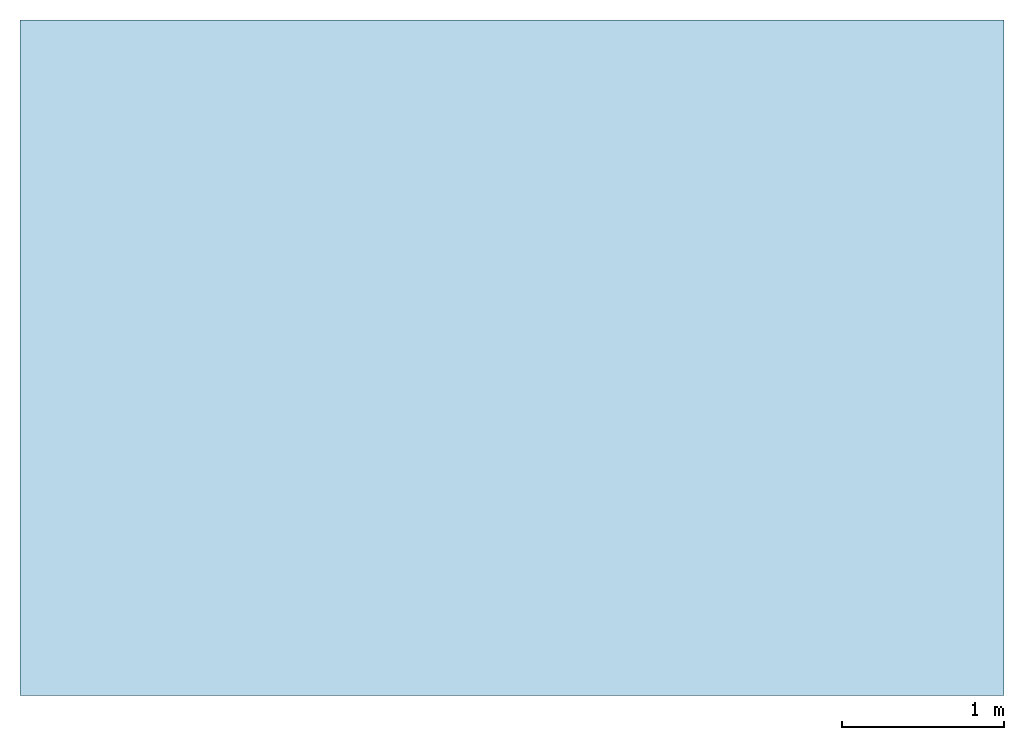
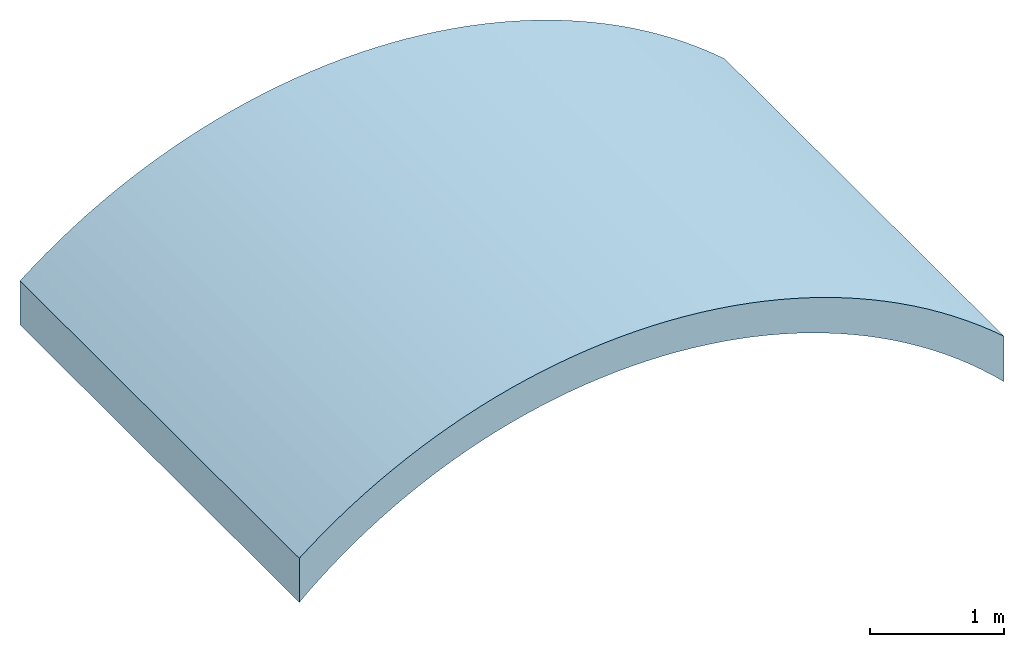
# One storey: 1 roof.
"""IFC4 building model written with IfcOpenShell, lengths in feet."""

from ifc_helpers import new_model, entity, si_unit, converted_unit, derived_unit, direction, frame, origin, place, context, subcontext, project, spatial, material, layer, layer_set, type_object, element, save


model = new_model("IFC4")

# Units and contexts
model_context = context("Model", 3, precision=0.0001, world=origin(), true_north=direction((6.12303176911189e-17, 1.0)))
body_context = subcontext(model_context, "Body", "Model", "MODEL_VIEW")
ifc_project = project(units=[converted_unit("LENGTHUNIT", "FOOT", entity("IfcRatioMeasure", 0.3048), si_unit("LENGTHUNIT", "METRE"), dimensions=[1, 0, 0, 0, 0, 0, 0]), converted_unit("AREAUNIT", "SQUARE FOOT", entity("IfcRatioMeasure", 0.09290304), si_unit("AREAUNIT", "SQUARE_METRE"), dimensions=[2, 0, 0, 0, 0, 0, 0]), converted_unit("VOLUMEUNIT", "CUBIC FOOT", entity("IfcRatioMeasure", 0.028316846592), si_unit("VOLUMEUNIT", "CUBIC_METRE"), dimensions=[3, 0, 0, 0, 0, 0, 0]), converted_unit("PLANEANGLEUNIT", "DEGREE", entity("IfcRatioMeasure", 0.0174532925199433), si_unit("PLANEANGLEUNIT", "RADIAN"), dimensions=[0, 0, 0, 0, 0, 0, 0]), si_unit("MASSUNIT", "GRAM", prefix="KILO"), derived_unit("MASSDENSITYUNIT", [(si_unit("MASSUNIT", "GRAM", prefix="KILO"), 1), (si_unit("LENGTHUNIT", "METRE"), -3)]), derived_unit("MOMENTOFINERTIAUNIT", [(si_unit("LENGTHUNIT", "METRE"), 4)]), si_unit("TIMEUNIT", "SECOND"), si_unit("FREQUENCYUNIT", "HERTZ"), si_unit("THERMODYNAMICTEMPERATUREUNIT", "DEGREE_CELSIUS"), derived_unit("THERMALTRANSMITTANCEUNIT", [(si_unit("MASSUNIT", "GRAM", prefix="KILO"), 1), (si_unit("THERMODYNAMICTEMPERATUREUNIT", "KELVIN"), -1), (si_unit("TIMEUNIT", "SECOND"), -3)]), derived_unit("VOLUMETRICFLOWRATEUNIT", [(si_unit("LENGTHUNIT", "METRE"), 3), (si_unit("TIMEUNIT", "SECOND"), -1)]), si_unit("ELECTRICCURRENTUNIT", "AMPERE"), si_unit("ELECTRICVOLTAGEUNIT", "VOLT"), si_unit("POWERUNIT", "WATT"), si_unit("FORCEUNIT", "NEWTON"), si_unit("ILLUMINANCEUNIT", "LUX"), si_unit("LUMINOUSFLUXUNIT", "LUMEN"), si_unit("LUMINOUSINTENSITYUNIT", "CANDELA"), derived_unit("USERDEFINED", [(si_unit("MASSUNIT", "GRAM", prefix="KILO"), -1), (si_unit("LENGTHUNIT", "METRE"), -2), (si_unit("TIMEUNIT", "SECOND"), 3), (si_unit("LUMINOUSFLUXUNIT", "LUMEN"), 1)]), derived_unit("LINEARVELOCITYUNIT", [(si_unit("LENGTHUNIT", "METRE"), 1), (si_unit("TIMEUNIT", "SECOND"), -1)]), si_unit("PRESSUREUNIT", "PASCAL"), derived_unit("USERDEFINED", [(si_unit("LENGTHUNIT", "METRE"), -2), (si_unit("MASSUNIT", "GRAM", prefix="KILO"), 1), (si_unit("TIMEUNIT", "SECOND"), -2)]), derived_unit("LINEARFORCEUNIT", [(si_unit("MASSUNIT", "GRAM", prefix="KILO"), 1), (si_unit("LENGTHUNIT", "METRE"), 1), (si_unit("TIMEUNIT", "SECOND"), -2), (si_unit("LENGTHUNIT", "METRE"), -1)]), derived_unit("PLANARFORCEUNIT", [(si_unit("MASSUNIT", "GRAM", prefix="KILO"), 1), (si_unit("LENGTHUNIT", "METRE"), 1), (si_unit("TIMEUNIT", "SECOND"), -2), (si_unit("LENGTHUNIT", "METRE"), -2)])], contexts=[model_context])

# Site, building, storey
site_placement = place(None, origin())
site = spatial("IfcSite", under=ifc_project, at=site_placement, CompositionType="ELEMENT")
building_placement = place(site_placement, origin())
building = spatial("IfcBuilding", under=site, at=building_placement, CompositionType="ELEMENT")
storey_placement = place(building_placement, frame((0.0, 0.0, 10.0)))
storey = spatial("IfcBuildingStorey", under=building, at=storey_placement, Name="Level 2", CompositionType="ELEMENT", Elevation=10.0)

# Roof
ifc_material = material(Name="Default Roof", Category="Materials")
ifc_layer = layer(ifc_material, 1.0, Name="Layer", Category="Materials")
ifc_layer_set = layer_set([ifc_layer])
roof_type = type_object("IfcRoofType", PredefinedType="NOTDEFINED")
roof_placement = place(storey_placement, frame((-4.75969989406747, -5.86136657261792, 0.340807190916026)))
cartesian_point_1 = entity("IfcCartesianPoint", [19.9189043479452, 0.0, 1.36562543667424])
vertex_point_1 = entity("IfcVertexPoint", cartesian_point_1)
cartesian_point_2 = entity("IfcCartesianPoint", [0.00523383279508405, 0.0, 1.70495521166711])
vertex_point_2 = entity("IfcVertexPoint", cartesian_point_2)
cartesian_point_3 = entity("IfcCartesianPoint", [9.75969989406745, 0.0, -10.340807190916])
ifc_direction_1 = entity("IfcDirection", [0.0, -1.0, 0.0])
ifc_direction_2 = entity("IfcDirection", [1.0, 0.0, 0.0])
edge_curve_1 = entity("IfcEdgeCurve", vertex_point_1, vertex_point_2, entity("IfcTrimmedCurve", entity("IfcCircle", entity("IfcAxis2Placement3D", cartesian_point_3, ifc_direction_1, ifc_direction_2), 15.5), [cartesian_point_1], [cartesian_point_2], True, "CARTESIAN"), True)
cartesian_point_4 = entity("IfcCartesianPoint", [0.00523383279499878, 0.0, 0.387677877325611])
vertex_point_3 = entity("IfcVertexPoint", cartesian_point_4)
ifc_direction_3 = entity("IfcDirection", [0.0, 0.0, -1.0])
edge_curve_2 = entity("IfcEdgeCurve", vertex_point_2, vertex_point_3, entity("IfcTrimmedCurve", entity("IfcLine", cartesian_point_2, entity("IfcVector", ifc_direction_3, 1.0)), [cartesian_point_2], [cartesian_point_4], True, "CARTESIAN"), True)
cartesian_point_5 = entity("IfcCartesianPoint", [19.9189043479452, 0.0, 0.00523383279499967])
vertex_point_4 = entity("IfcVertexPoint", cartesian_point_5)
ifc_direction_4 = entity("IfcDirection", [0.0, 1.0, 0.0])
edge_curve_3 = entity("IfcEdgeCurve", vertex_point_3, vertex_point_4, entity("IfcTrimmedCurve", entity("IfcCircle", entity("IfcAxis2Placement3D", cartesian_point_3, ifc_direction_4, ifc_direction_2), 14.5), [cartesian_point_4], [cartesian_point_5], True, "CARTESIAN"), True)
ifc_direction_5 = entity("IfcDirection", [0.0, 0.0, 1.0])
edge_curve_4 = entity("IfcEdgeCurve", vertex_point_4, vertex_point_1, entity("IfcTrimmedCurve", entity("IfcLine", cartesian_point_5, entity("IfcVector", ifc_direction_5, 1.0)), [cartesian_point_5], [cartesian_point_1], True, "CARTESIAN"), True)
cartesian_point_6 = entity("IfcCartesianPoint", [19.9189043479452, 13.6701224547512, 1.36562543667431])
vertex_point_5 = entity("IfcVertexPoint", cartesian_point_6)
cartesian_point_7 = entity("IfcCartesianPoint", [19.9189043479452, 13.6701224547512, 0.00523383279500145])
vertex_point_6 = entity("IfcVertexPoint", cartesian_point_7)
edge_curve_5 = entity("IfcEdgeCurve", vertex_point_5, vertex_point_6, entity("IfcTrimmedCurve", entity("IfcLine", cartesian_point_6, entity("IfcVector", ifc_direction_3, 1.0)), [cartesian_point_6], [cartesian_point_7], True, "CARTESIAN"), True)
cartesian_point_8 = entity("IfcCartesianPoint", [0.00523383279503786, 13.6701224547513, 0.387677877325611])
vertex_point_7 = entity("IfcVertexPoint", cartesian_point_8)
cartesian_point_9 = entity("IfcCartesianPoint", [9.75969989406749, 13.6701224547513, -10.340807190916])
edge_curve_6 = entity("IfcEdgeCurve", vertex_point_6, vertex_point_7, entity("IfcTrimmedCurve", entity("IfcCircle", entity("IfcAxis2Placement3D", cartesian_point_9, ifc_direction_1, ifc_direction_2), 14.5), [cartesian_point_7], [cartesian_point_8], True, "CARTESIAN"), True)
cartesian_point_10 = entity("IfcCartesianPoint", [0.00523383279503786, 13.6701224547513, 1.70495521166704])
vertex_point_8 = entity("IfcVertexPoint", cartesian_point_10)
edge_curve_7 = entity("IfcEdgeCurve", vertex_point_7, vertex_point_8, entity("IfcTrimmedCurve", entity("IfcLine", cartesian_point_8, entity("IfcVector", ifc_direction_5, 1.0)), [cartesian_point_8], [cartesian_point_10], True, "CARTESIAN"), True)
edge_curve_8 = entity("IfcEdgeCurve", vertex_point_8, vertex_point_5, entity("IfcTrimmedCurve", entity("IfcCircle", entity("IfcAxis2Placement3D", cartesian_point_9, ifc_direction_4, ifc_direction_2), 15.5), [cartesian_point_10], [cartesian_point_6], True, "CARTESIAN"), True)
edge_curve_9 = entity("IfcEdgeCurve", vertex_point_1, vertex_point_5, entity("IfcTrimmedCurve", entity("IfcLine", cartesian_point_1, entity("IfcVector", ifc_direction_4, 1.0)), [cartesian_point_1], [cartesian_point_6], True, "CARTESIAN"), True)
edge_curve_10 = entity("IfcEdgeCurve", vertex_point_8, vertex_point_2, entity("IfcTrimmedCurve", entity("IfcLine", cartesian_point_2, entity("IfcVector", ifc_direction_1, 1.0)), [cartesian_point_10], [cartesian_point_2], True, "CARTESIAN"), True)
edge_curve_11 = entity("IfcEdgeCurve", vertex_point_7, vertex_point_3, entity("IfcTrimmedCurve", entity("IfcLine", cartesian_point_4, entity("IfcVector", ifc_direction_1, 1.0)), [cartesian_point_8], [cartesian_point_4], True, "CARTESIAN"), True)
edge_curve_12 = entity("IfcEdgeCurve", vertex_point_6, vertex_point_4, entity("IfcTrimmedCurve", entity("IfcLine", cartesian_point_5, entity("IfcVector", ifc_direction_1, 1.0)), [cartesian_point_7], [cartesian_point_5], True, "CARTESIAN"), True)
element("IfcRoof", 1, at=roof_placement, inside=storey, type_object=roof_type, material=ifc_layer_set, PredefinedType="NOTDEFINED", context=body_context, shape_type="AdvancedBrep", body=[
    entity("IfcAdvancedBrep", entity("IfcClosedShell", [entity("IfcAdvancedFace", [entity("IfcFaceOuterBound", entity("IfcEdgeLoop", [entity("IfcOrientedEdge", None, None, edge_curve_1, True), entity("IfcOrientedEdge", None, None, edge_curve_2, True), entity("IfcOrientedEdge", None, None, edge_curve_3, True), entity("IfcOrientedEdge", None, None, edge_curve_4, True)]), True)], entity("IfcPlane", entity("IfcAxis2Placement3D", entity("IfcCartesianPoint", [25.2596998940675, 0.0, -10.340807190916]), ifc_direction_1, ifc_direction_5)), True), entity("IfcAdvancedFace", [entity("IfcFaceOuterBound", entity("IfcEdgeLoop", [entity("IfcOrientedEdge", None, None, edge_curve_5, True), entity("IfcOrientedEdge", None, None, edge_curve_6, True), entity("IfcOrientedEdge", None, None, edge_curve_7, True), entity("IfcOrientedEdge", None, None, edge_curve_8, True)]), True)], entity("IfcPlane", entity("IfcAxis2Placement3D", entity("IfcCartesianPoint", [25.2596998940675, 13.6701224547512, -10.340807190916]), ifc_direction_4, ifc_direction_3)), True), entity("IfcAdvancedFace", [entity("IfcFaceOuterBound", entity("IfcEdgeLoop", [entity("IfcOrientedEdge", None, None, edge_curve_1, False), entity("IfcOrientedEdge", None, None, edge_curve_9, True), entity("IfcOrientedEdge", None, None, edge_curve_8, False), entity("IfcOrientedEdge", None, None, edge_curve_10, True)]), True)], entity("IfcCylindricalSurface", entity("IfcAxis2Placement3D", cartesian_point_9, ifc_direction_1, ifc_direction_2), 15.5), True), entity("IfcAdvancedFace", [entity("IfcFaceOuterBound", entity("IfcEdgeLoop", [entity("IfcOrientedEdge", None, None, edge_curve_2, False), entity("IfcOrientedEdge", None, None, edge_curve_10, False), entity("IfcOrientedEdge", None, None, edge_curve_7, False), entity("IfcOrientedEdge", None, None, edge_curve_11, True)]), True)], entity("IfcPlane", entity("IfcAxis2Placement3D", cartesian_point_2, entity("IfcDirection", [-1.0, 0.0, 0.0]), ifc_direction_4)), True), entity("IfcAdvancedFace", [entity("IfcFaceOuterBound", entity("IfcEdgeLoop", [entity("IfcOrientedEdge", None, None, edge_curve_3, False), entity("IfcOrientedEdge", None, None, edge_curve_11, False), entity("IfcOrientedEdge", None, None, edge_curve_6, False), entity("IfcOrientedEdge", None, None, edge_curve_12, True)]), True)], entity("IfcCylindricalSurface", entity("IfcAxis2Placement3D", cartesian_point_9, ifc_direction_4, ifc_direction_2), 14.5), False), entity("IfcAdvancedFace", [entity("IfcFaceOuterBound", entity("IfcEdgeLoop", [entity("IfcOrientedEdge", None, None, edge_curve_4, False), entity("IfcOrientedEdge", None, None, edge_curve_12, False), entity("IfcOrientedEdge", None, None, edge_curve_5, False), entity("IfcOrientedEdge", None, None, edge_curve_9, False)]), True)], entity("IfcPlane", entity("IfcAxis2Placement3D", cartesian_point_5, ifc_direction_2, ifc_direction_4)), True)])),
])

save(model, "model.ifc")
